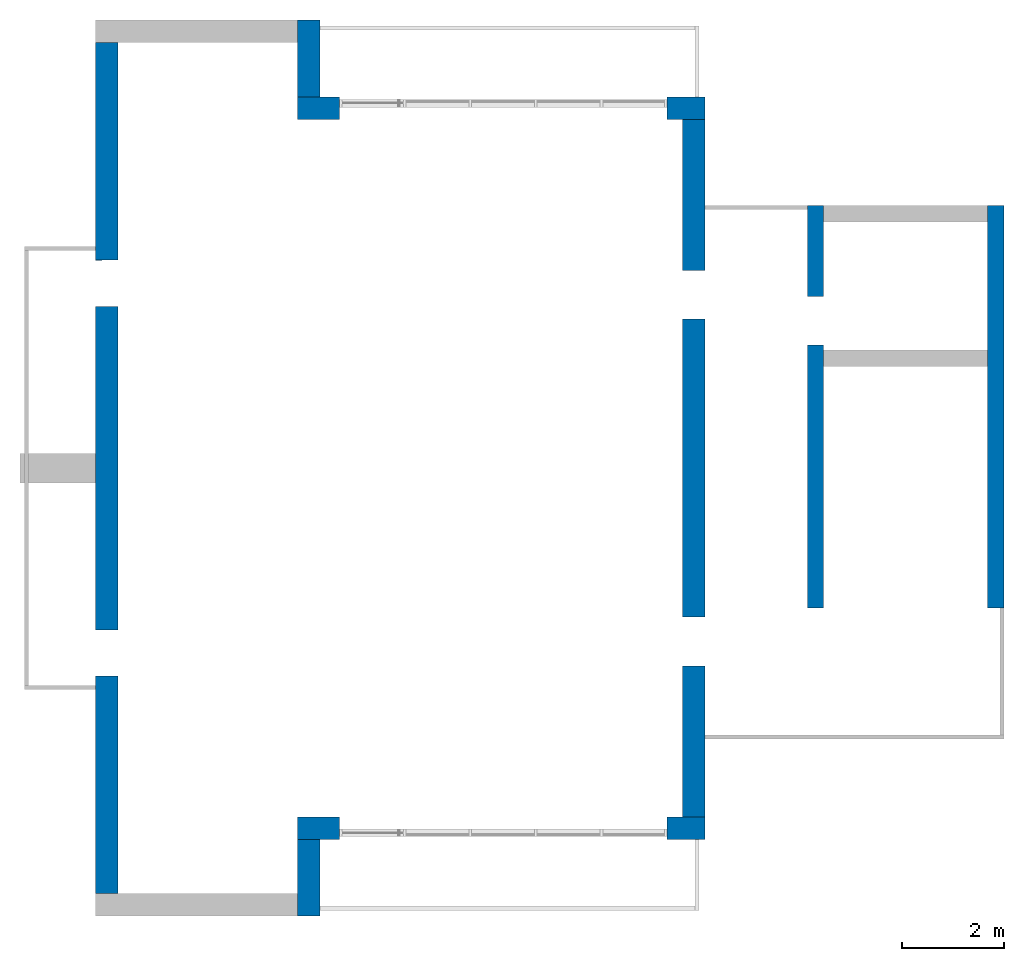
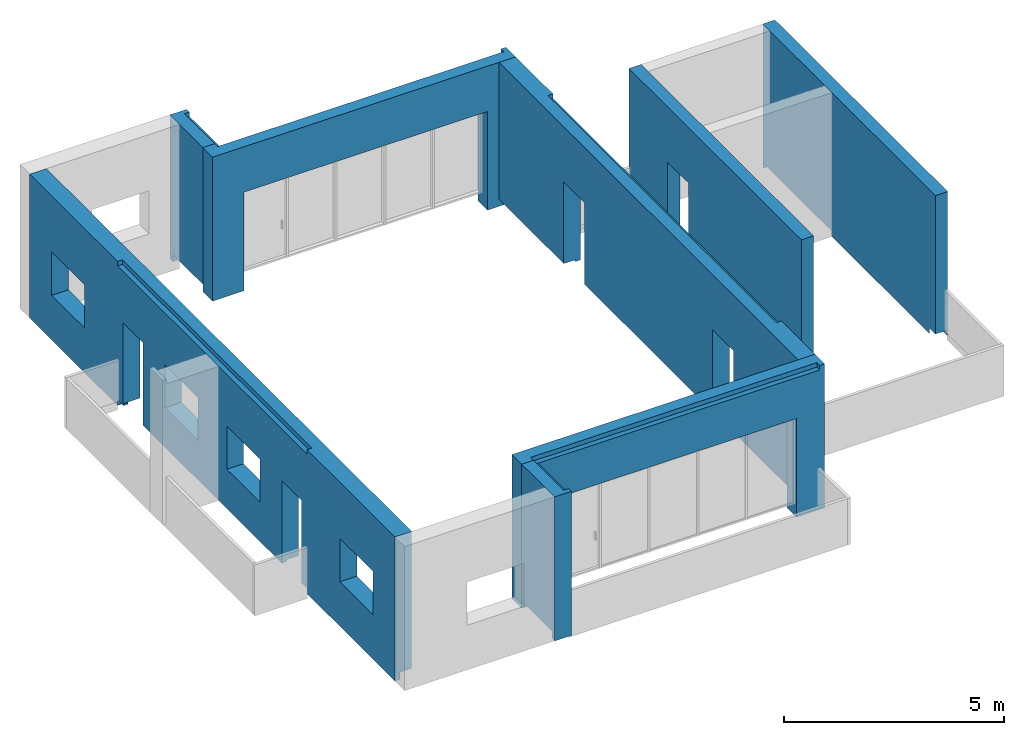
# One storey, part 3 of 4: 8 walls.
"""IFC2X3 building model written with IfcOpenShell, lengths in millimetres."""

from ifc_helpers import new_model, entity, si_unit, converted_unit, derived_unit, direction, frame, origin, place, context, subcontext, project, spatial, faceted_brep, material, layer, layer_set, type_object, element, save


model = new_model("IFC2X3")

# Units and contexts
model_context = context("Model", 3, precision=0.01, world=origin(), true_north=direction((6.12303176911189e-17, 1.0)))
body_context = subcontext(model_context, "Body", "Model", "MODEL_VIEW")
ifc_project = project(units=[si_unit("LENGTHUNIT", "METRE", prefix="MILLI"), si_unit("AREAUNIT", "SQUARE_METRE"), si_unit("VOLUMEUNIT", "CUBIC_METRE"), converted_unit("PLANEANGLEUNIT", "DEGREE", entity("IfcRatioMeasure", 0.0174532925199433), si_unit("PLANEANGLEUNIT", "RADIAN"), dimensions=[0, 0, 0, 0, 0, 0, 0]), si_unit("MASSUNIT", "GRAM", prefix="KILO"), derived_unit("MASSDENSITYUNIT", [(si_unit("MASSUNIT", "GRAM", prefix="KILO"), 1), (si_unit("LENGTHUNIT", "METRE"), -3)]), si_unit("TIMEUNIT", "SECOND"), si_unit("FREQUENCYUNIT", "HERTZ"), si_unit("THERMODYNAMICTEMPERATUREUNIT", "DEGREE_CELSIUS"), derived_unit("THERMALTRANSMITTANCEUNIT", [(si_unit("MASSUNIT", "GRAM", prefix="KILO"), 1), (si_unit("THERMODYNAMICTEMPERATUREUNIT", "KELVIN"), -1), (si_unit("TIMEUNIT", "SECOND"), -3)]), derived_unit("VOLUMETRICFLOWRATEUNIT", [(si_unit("LENGTHUNIT", "METRE"), 3), (si_unit("TIMEUNIT", "SECOND"), -1)]), si_unit("ELECTRICCURRENTUNIT", "AMPERE"), si_unit("ELECTRICVOLTAGEUNIT", "VOLT"), si_unit("POWERUNIT", "WATT"), si_unit("FORCEUNIT", "NEWTON", prefix="KILO"), si_unit("ILLUMINANCEUNIT", "LUX"), si_unit("LUMINOUSFLUXUNIT", "LUMEN"), si_unit("LUMINOUSINTENSITYUNIT", "CANDELA"), derived_unit("USERDEFINED", [(si_unit("MASSUNIT", "GRAM", prefix="KILO"), -1), (si_unit("LENGTHUNIT", "METRE"), -2), (si_unit("TIMEUNIT", "SECOND"), 3), (si_unit("LUMINOUSFLUXUNIT", "LUMEN"), 1)]), derived_unit("LINEARVELOCITYUNIT", [(si_unit("LENGTHUNIT", "METRE"), 1), (si_unit("TIMEUNIT", "SECOND"), -1)]), si_unit("PRESSUREUNIT", "PASCAL"), derived_unit("USERDEFINED", [(si_unit("LENGTHUNIT", "METRE"), -2), (si_unit("MASSUNIT", "GRAM", prefix="KILO"), 1), (si_unit("TIMEUNIT", "SECOND"), -2)])], contexts=[model_context])

# Site, building, storey
site_placement = place(None, origin())
site = spatial("IfcSite", under=ifc_project, at=site_placement, CompositionType="ELEMENT")
building_placement = place(site_placement, origin())
building = spatial("IfcBuilding", under=site, at=building_placement, CompositionType="ELEMENT")
storey_placement = place(building_placement, frame((0.0, 0.0, 8000.0)))
storey = spatial("IfcBuildingStorey", under=building, at=storey_placement, Name="02 Level", CompositionType="ELEMENT", Elevation=8000.0)

# Walls
ifc_material_1 = material(Name="03")
ifc_layer_1 = layer(ifc_material_1, 10.0)
ifc_material_2 = material()
ifc_layer_2 = layer(ifc_material_2, 120.0)
ifc_material_3 = material()
ifc_layer_3 = layer(ifc_material_3, 300.0)
ifc_layer_4 = layer(ifc_material_1, 10.0)
ifc_layer_set_1 = layer_set([ifc_layer_1, ifc_layer_2, ifc_layer_3, ifc_layer_4], Name="Basic Wall:00_fal+12 cm")
wall_type_1 = type_object("IfcWallType", Name="Basic Wall:00_fal+12 cm", PredefinedType="STANDARD", material=ifc_layer_set_1)
wall_1_placement = place(storey_placement, frame((28723.4900708518, -62021.23958514, -340.0), z_axis=(0.0, 0.0, 1.0), x_axis=(0.0, -1.0, 0.0)))
element("IfcWall", 1, at=wall_1_placement, inside=storey, type_object=wall_type_1, Name="Basic Wall:00_fal+12 cm", ObjectType="Basic Wall:00_fal+12 cm", context=body_context, shape_type="Brep", body=[
    faceted_brep([(13620.0, -220.0, 4000.0), (9620.0, -220.0, 4000.0), (9470.0, -220.0, 4000.0), (6970.0, -220.0, 4000.0), (6650.0, -220.0, 4000.0), (4150.0, -220.0, 4000.0), (4000.0, -220.0, 4000.0), (0.0, -220.0, 4000.0), (0.0, -220.0, 200.0), (2950.0, -220.0, 200.0), (2950.0, -220.0, 340.0), (2950.0, -220.0, 2465.0), (3900.0, -220.0, 2465.0), (3900.0, -220.0, 340.0), (3900.0, -220.0, 200.0), (4000.0, -220.0, 200.0), (4150.0, -220.0, 200.0), (6650.0, -220.0, 200.0), (6970.0, -220.0, 200.0), (9470.0, -220.0, 200.0), (9620.0, -220.0, 200.0), (9720.0, -220.0, 200.0), (9720.0, -220.0, 340.0), (9720.0, -220.0, 2465.0), (10670.0, -220.0, 2465.0), (10670.0, -220.0, 340.0), (10670.0, -220.0, 200.0), (13620.0, -220.0, 200.0), (10670.0, 220.0, 2465.0), (9720.0, 220.0, 2465.0), (9720.0, 220.0, 340.0), (9720.0, 220.0, 150.0), (3900.0, 220.0, 150.0), (3900.0, 220.0, 340.0), (3900.0, 220.0, 2465.0), (2950.0, 220.0, 2465.0), (2950.0, 220.0, 340.0), (2950.0, 220.0, 150.0), (1764.58460545632, 220.0, 150.0), (1694.58460545634, 220.0, 150.0), (1694.58460545634, 220.0, 0.0), (0.0, 220.0, 0.0), (0.0, 220.0, 4000.0), (1694.58460545634, 220.0, 4000.0), (1699.58460545631, 220.0, 4000.0), (1699.58460545631, 220.0, 3875.0), (12094.5846054563, 220.0, 3875.0), (12094.5846054563, 220.0, 4000.0), (13620.0, 220.0, 4000.0), (13620.0, 220.0, 0.0), (12094.5846054563, 220.0, 0.0), (12039.5846054563, 220.0, 0.0), (12039.5846054563, 220.0, 150.0), (12024.5846054563, 220.0, 150.0), (10670.0, 220.0, 150.0), (10670.0, 220.0, 340.0), (1694.58460545634, 90.0, 0.0), (0.0, 90.0, 0.0), (12094.5846054563, 90.0, 4000.0), (1699.58460545631, 90.0, 4000.0), (0.0, 90.0, 4000.0), (9720.0, -120.0, 200.0), (9720.0, 90.0, 200.0), (9720.0, 90.0, 150.0), (10670.0, 90.0, 150.0), (10670.0, 90.0, 200.0), (10670.0, -120.0, 200.0), (3900.0, 90.0, 150.0), (3900.0, 90.0, 200.0), (3900.0, -120.0, 200.0), (2950.0, -120.0, 200.0), (2950.0, 90.0, 200.0), (2950.0, 90.0, 150.0), (13620.0, 90.0, 200.0), (1694.58460545634, 90.0, 150.0), (0.0, 90.0, 200.0), (12039.5846054563, 90.0, 150.0), (12039.5846054563, 90.0, 0.0), (13620.0, 90.0, 0.0), (1699.58460545631, 90.0, 3875.0), (12094.5846054563, 90.0, 3875.0)], [[[0, 1, 2, 3, 4, 5, 6, 7, 8, 9, 10, 11, 12, 13, 14, 15, 16, 17, 18, 19, 20, 21, 22, 23, 24, 25, 26, 27]], [[28, 29, 30, 31, 32, 33, 34, 35, 36, 37, 38, 39, 40, 41, 42, 43, 44, 45, 46, 47, 48, 49, 50, 51, 52, 53, 54, 55]], [[41, 40, 56, 57]], [[7, 6, 5, 4, 3, 2, 1, 0, 48, 47, 58, 59, 44, 43, 42, 60]], [[29, 23, 22, 21, 61, 62, 63, 31, 30]], [[24, 23, 29, 28]], [[24, 28, 55, 54, 64, 65, 66, 26, 25]], [[12, 34, 33, 32, 67, 68, 69, 14, 13]], [[12, 11, 35, 34]], [[35, 11, 10, 9, 70, 71, 72, 37, 36]], [[73, 27, 26, 66, 65]], [[57, 56, 74, 72, 71, 75]], [[52, 76, 64, 54, 53]], [[76, 52, 51, 77]], [[39, 74, 56, 40]], [[48, 0, 27, 73, 78, 49]], [[7, 60, 42, 41, 57, 75, 8]], [[79, 80, 46, 45]], [[80, 79, 59, 58]], [[59, 79, 45, 44]], [[80, 58, 47, 46]], [[63, 67, 32, 31]], [[74, 39, 38, 37, 72]], [[77, 78, 73, 65, 64, 76]], [[62, 68, 67, 63]], [[8, 75, 71, 70, 9]], [[21, 20, 19, 18, 17, 16, 15, 14, 69, 68, 62, 61]], [[51, 50, 49, 78, 77]]]),
])
wall_2_placement = place(storey_placement, frame((21203.4900708518, -76081.2395851399, -340.0), z_axis=(0.0, 0.0, 1.0), x_axis=(0.0, -1.0, 0.0)))
element("IfcWall", 2, at=wall_2_placement, inside=storey, type_object=wall_type_1, Name="Basic Wall:00_fal+12 cm", ObjectType="Basic Wall:00_fal+12 cm", context=body_context, shape_type="Brep", body=[
    faceted_brep([(1500.0, -220.0, 4000.0), (1370.0, -220.0, 4000.0), (1060.0, -220.0, 4000.0), (0.0, -220.0, 4000.0), (0.0, -220.0, 200.0), (1370.0, -220.0, 200.0), (1370.0, -220.0, 0.0), (1500.0, -220.0, 0.0), (1500.0, 220.0, 4000.0), (1500.0, 220.0, 0.0), (1370.0, 220.0, 0.0), (1370.0, 220.0, 150.0), (1305.0, 220.0, 150.0), (0.0, 220.0, 150.0), (0.0, 220.0, 3875.0), (1370.0, 220.0, 3875.0), (1370.0, 220.0, 4000.0), (1370.0, 90.0, 0.0), (1370.0, 90.0, 4000.0), (0.0, 90.0, 4000.0), (1370.0, 90.0, 200.0), (0.0, 90.0, 200.0), (1370.0, 90.0, 150.0), (0.0, 90.0, 150.0), (0.0, 90.0, 3875.0), (1370.0, 90.0, 3875.0)], [[[0, 1, 2, 3, 4, 5, 6, 7]], [[8, 9, 10, 11, 12, 13, 14, 15, 16]], [[9, 7, 6, 17, 10]], [[3, 2, 1, 0, 8, 16, 18, 19]], [[7, 9, 8, 0]], [[20, 5, 4, 21]], [[22, 20, 21, 23]], [[5, 20, 22, 11, 10, 17, 6]], [[11, 22, 23, 13, 12]], [[24, 25, 15, 14]], [[25, 18, 16, 15]], [[18, 25, 24, 19]], [[4, 3, 19, 24, 14, 13, 23, 21]]]),
])
wall_3_placement = place(storey_placement, frame((17263.4900708518, -77141.2395851399, -340.0), z_axis=(0.0, 0.0, 1.0), x_axis=(0.0, 1.0, 0.0)))
element("IfcWall", 3, at=wall_3_placement, inside=storey, type_object=wall_type_1, Name="Basic Wall:00_fal+12 cm", ObjectType="Basic Wall:00_fal+12 cm", context=body_context, shape_type="Brep", body=[
    faceted_brep([(16620.0, -220.0, 4000.0), (12620.0, -220.0, 4000.0), (12470.0, -220.0, 4000.0), (8470.0, -220.0, 4000.0), (8150.0, -220.0, 4000.0), (4150.0, -220.0, 4000.0), (4000.0, -220.0, 4000.0), (0.0, -220.0, 4000.0), (0.0, -220.0, 200.0), (4000.0, -220.0, 200.0), (4150.0, -220.0, 200.0), (4250.0, -220.0, 200.0), (4250.0, -220.0, 2440.0), (5150.0, -220.0, 2440.0), (5150.0, -220.0, 200.0), (8150.0, -220.0, 200.0), (8470.0, -220.0, 200.0), (11470.0, -220.0, 200.0), (11470.0, -220.0, 2440.0), (12370.0, -220.0, 2440.0), (12370.0, -220.0, 200.0), (12470.0, -220.0, 200.0), (12620.0, -220.0, 200.0), (16620.0, -220.0, 200.0), (7650.0, -220.0, 2440.0), (7650.0, -220.0, 1240.0), (6150.0, -220.0, 1240.0), (6150.0, -220.0, 2440.0), (2500.0, -220.0, 2440.0), (2500.0, -220.0, 1240.0), (1000.0, -220.0, 1240.0), (1000.0, -220.0, 2440.0), (8970.0, -220.0, 1240.0), (8970.0, -220.0, 2440.0), (10470.0, -220.0, 2440.0), (10470.0, -220.0, 1240.0), (14120.0, -220.0, 1240.0), (14120.0, -220.0, 2440.0), (15620.0, -220.0, 2440.0), (15620.0, -220.0, 1240.0), (0.0, 220.0, 0.0), (0.0, 220.0, 4000.0), (4000.0, 220.0, 4000.0), (4000.0, 220.0, 3875.0), (8020.0, 220.0, 3875.0), (8590.0, 220.0, 3875.0), (12620.0, 220.0, 3875.0), (12620.0, 220.0, 4000.0), (16620.0, 220.0, 4000.0), (16620.0, 220.0, 0.0), (12620.0, 220.0, 0.0), (12620.0, 220.0, 150.0), (12555.0, 220.0, 150.0), (12360.0, 220.0, 150.0), (12360.0, 220.0, 200.0), (12370.0, 220.0, 200.0), (12370.0, 220.0, 340.0), (12370.0, 220.0, 2440.0), (11470.0, 220.0, 2440.0), (11470.0, 220.0, 340.0), (11460.0, 220.0, 340.0), (11460.0, 220.0, 150.0), (8590.0, 220.0, 150.0), (8020.0, 220.0, 150.0), (5150.0, 220.0, 150.0), (5150.0, 220.0, 340.0), (5150.0, 220.0, 2440.0), (4250.0, 220.0, 2440.0), (4250.0, 220.0, 340.0), (4250.0, 220.0, 150.0), (4065.0, 220.0, 150.0), (4000.0, 220.0, 150.0), (4000.0, 220.0, 0.0), (7650.0, 220.0, 1240.0), (7650.0, 220.0, 2440.0), (6150.0, 220.0, 2440.0), (6150.0, 220.0, 1240.0), (2500.0, 220.0, 1240.0), (2500.0, 220.0, 2440.0), (1000.0, 220.0, 2440.0), (1000.0, 220.0, 1240.0), (8970.0, 220.0, 2440.0), (8970.0, 220.0, 1240.0), (10470.0, 220.0, 1240.0), (10470.0, 220.0, 2440.0), (14120.0, 220.0, 2440.0), (14120.0, 220.0, 1240.0), (15620.0, 220.0, 1240.0), (15620.0, 220.0, 2440.0), (0.0, 90.0, 0.0), (4000.0, 90.0, 0.0), (16620.0, 90.0, 4000.0), (12620.0, 90.0, 4000.0), (4000.0, 90.0, 4000.0), (0.0, 90.0, 4000.0), (0.0, 90.0, 200.0), (4250.0, -120.0, 200.0), (4250.0, 90.0, 200.0), (4250.0, 90.0, 150.0), (5150.0, 90.0, 150.0), (5150.0, 90.0, 200.0), (5150.0, -120.0, 200.0), (16620.0, 90.0, 200.0), (16620.0, 90.0, 0.0), (12370.0, 90.0, 200.0), (12360.0, 90.0, 200.0), (11470.0, -120.0, 200.0), (11470.0, -120.0, 340.0), (4000.0, 90.0, 150.0), (12620.0, 90.0, 150.0), (12620.0, 90.0, 0.0), (4000.0, 90.0, 3875.0), (12620.0, 90.0, 3875.0), (11460.0, -120.0, 340.0), (11460.0, -120.0, 200.0), (11460.0, 90.0, 200.0), (11460.0, 90.0, 150.0), (12360.0, 90.0, 150.0)], [[[0, 1, 2, 3, 4, 5, 6, 7, 8, 9, 10, 11, 12, 13, 14, 15, 16, 17, 18, 19, 20, 21, 22, 23], [24, 25, 26, 27], [28, 29, 30, 31], [32, 33, 34, 35], [36, 37, 38, 39]], [[40, 41, 42, 43, 44, 45, 46, 47, 48, 49, 50, 51, 52, 53, 54, 55, 56, 57, 58, 59, 60, 61, 62, 63, 64, 65, 66, 67, 68, 69, 70, 71, 72], [73, 74, 75, 76], [77, 78, 79, 80], [81, 82, 83, 84], [85, 86, 87, 88]], [[89, 40, 72, 90]], [[7, 6, 5, 4, 3, 2, 1, 0, 91, 48, 47, 92, 93, 42, 41, 94]], [[7, 94, 41, 40, 89, 95, 8]], [[12, 11, 96, 97, 98, 69, 68, 67]], [[13, 12, 67, 66]], [[14, 13, 66, 65, 64, 99, 100, 101]], [[49, 48, 91, 0, 23, 102, 103]], [[104, 55, 54, 105]], [[20, 19, 57, 56, 55, 104]], [[58, 57, 19, 18]], [[18, 17, 106, 107, 59, 58]], [[74, 73, 25, 24]], [[75, 74, 24, 27]], [[76, 75, 27, 26]], [[73, 76, 26, 25]], [[78, 77, 29, 28]], [[79, 78, 28, 31]], [[80, 79, 31, 30]], [[77, 80, 30, 29]], [[33, 32, 82, 81]], [[34, 33, 81, 84]], [[35, 34, 84, 83]], [[32, 35, 83, 82]], [[37, 36, 86, 85]], [[38, 37, 85, 88]], [[39, 38, 88, 87]], [[36, 39, 87, 86]], [[23, 22, 21, 20, 104, 102]], [[95, 89, 90, 108, 98, 97]], [[108, 71, 70, 69, 98]], [[109, 51, 50, 110]], [[71, 108, 90, 72]], [[111, 112, 46, 45, 44, 43]], [[112, 92, 47, 46]], [[112, 111, 93, 92]], [[93, 111, 43, 42]], [[113, 60, 59, 107]], [[60, 113, 114, 115, 116, 61]], [[113, 107, 106, 114]], [[54, 53, 117, 105]], [[51, 109, 117, 53, 52]], [[64, 63, 62, 61, 116, 99]], [[100, 99, 116, 115]], [[103, 102, 104, 105, 117, 109, 110]], [[17, 16, 15, 14, 101, 100, 115, 114, 106]], [[8, 95, 97, 96, 11, 10, 9]], [[49, 103, 110, 50]]]),
])
wall_4_placement = place(storey_placement, frame((21203.4900708518, -61581.2395851399, -340.0), z_axis=(0.0, 0.0, 1.0), x_axis=(0.0, 1.0, 0.0)))
element("IfcWall", 4, at=wall_4_placement, inside=storey, type_object=wall_type_1, Name="Basic Wall:00_fal+12 cm", ObjectType="Basic Wall:00_fal+12 cm", context=body_context, shape_type="Brep", body=[
    faceted_brep([(1500.0, -220.0, 0.0), (1500.0, -220.0, 4000.0), (1370.0, -220.0, 4000.0), (1370.0, -220.0, 3875.0), (0.0, -220.0, 3875.0), (0.0, -220.0, 150.0), (1305.0, -220.0, 150.0), (1370.0, -220.0, 150.0), (1370.0, -220.0, 0.0), (0.0, 220.0, 4000.0), (1060.0, 220.0, 4000.0), (1370.0, 220.0, 4000.0), (1500.0, 220.0, 4000.0), (1500.0, 220.0, 0.0), (1370.0, 220.0, 0.0), (1370.0, 220.0, 200.0), (0.0, 220.0, 200.0), (1370.0, -90.0, 0.0), (0.0, -90.0, 4000.0), (1370.0, -90.0, 4000.0), (0.0, -90.0, 200.0), (0.0, -90.0, 150.0), (0.0, -90.0, 3875.0), (1370.0, -90.0, 200.0), (1370.0, -90.0, 150.0), (1370.0, -90.0, 3875.0)], [[[0, 1, 2, 3, 4, 5, 6, 7, 8]], [[9, 10, 11, 12, 13, 14, 15, 16]], [[13, 0, 8, 17, 14]], [[12, 11, 10, 9, 18, 19, 2, 1]], [[0, 13, 12, 1]], [[9, 16, 20, 21, 5, 4, 22, 18]], [[15, 23, 20, 16]], [[23, 15, 14, 17, 8, 7, 24]], [[20, 23, 24, 21]], [[24, 7, 6, 5, 21]], [[3, 25, 22, 4]], [[25, 19, 18, 22]], [[19, 25, 3, 2]]]),
])
wall_5_placement = place(storey_placement, frame((28943.4900708518, -75861.2395851399, -340.0), z_axis=(0.0, 0.0, 1.0), x_axis=(-1.0, 0.0, 0.0)))
element("IfcWall", 5, at=wall_5_placement, inside=storey, type_object=wall_type_1, Name="Basic Wall:00_fal+12 cm", ObjectType="Basic Wall:00_fal+12 cm", context=body_context, shape_type="Brep", body=[
    faceted_brep([(0.0, -220.0, 0.0), (130.0, -220.0, 0.0), (740.0, -220.0, 0.0), (740.0, -220.0, 200.0), (740.0, -220.0, 340.0), (740.0, -220.0, 2740.0), (7140.0, -220.0, 2740.0), (7140.0, -220.0, 340.0), (7140.0, -220.0, 200.0), (7140.0, -220.0, 0.0), (7960.0, -220.0, 0.0), (7960.0, -220.0, 200.0), (7960.0, -220.0, 4000.0), (7640.0, -220.0, 4000.0), (440.0, -220.0, 4000.0), (0.0, -220.0, 4000.0), (740.0, 220.0, 0.0), (0.0, 220.0, 0.0), (0.0, 220.0, 4000.0), (130.0, 220.0, 4000.0), (130.0, 220.0, 3875.0), (7520.0, 220.0, 3875.0), (7650.0, 220.0, 3875.0), (7650.0, 220.0, 4000.0), (7960.0, 220.0, 4000.0), (7960.0, 220.0, 200.0), (7960.0, 220.0, 0.0), (7140.0, 220.0, 0.0), (7140.0, 220.0, 150.0), (7140.0, 220.0, 340.0), (7140.0, 220.0, 2740.0), (740.0, 220.0, 2740.0), (740.0, 220.0, 340.0), (740.0, 220.0, 150.0), (7650.0, 90.0, 4000.0), (130.0, 90.0, 4000.0), (130.0, 90.0, 3875.0), (7650.0, 90.0, 3875.0)], [[[0, 1, 2, 3, 4, 5, 6, 7, 8, 9, 10, 11, 12, 13, 14, 15]], [[16, 17, 18, 19, 20, 21, 22, 23, 24, 25, 26, 27, 28, 29, 30, 31, 32, 33]], [[5, 31, 30, 6]], [[2, 1, 0, 17, 16]], [[15, 14, 13, 12, 24, 23, 34, 35, 19, 18]], [[31, 5, 4, 3, 2, 16, 33, 32]], [[6, 30, 29, 28, 27, 9, 8, 7]], [[10, 9, 27, 26]], [[17, 0, 15, 18]], [[10, 26, 25, 24, 12, 11]], [[36, 37, 22, 21, 20]], [[37, 36, 35, 34]], [[35, 36, 20, 19]], [[37, 34, 23, 22]]]),
])
wall_6_placement = place(storey_placement, frame((28943.4900708518, -61801.23958514, -340.0), z_axis=(0.0, 0.0, 1.0), x_axis=(-1.0, 0.0, 0.0)))
element("IfcWall", 6, at=wall_6_placement, inside=storey, type_object=wall_type_1, Name="Basic Wall:00_fal+12 cm", ObjectType="Basic Wall:00_fal+12 cm", context=body_context, shape_type="Brep", body=[
    faceted_brep([(0.0, -220.0, 0.0), (740.0, -220.0, 0.0), (740.0, -220.0, 150.0), (740.0, -220.0, 340.0), (740.0, -220.0, 2740.0), (7140.0, -220.0, 2740.0), (7140.0, -220.0, 340.0), (7140.0, -220.0, 150.0), (7140.0, -220.0, 0.0), (7520.0, -220.0, 0.0), (7960.0, -220.0, 0.0), (7960.0, -220.0, 4000.0), (7650.0, -220.0, 4000.0), (7650.0, -220.0, 3875.0), (130.0, -220.0, 3875.0), (130.0, -220.0, 4000.0), (0.0, -220.0, 4000.0), (740.0, 220.0, 0.0), (130.0, 220.0, 0.0), (0.0, 220.0, 0.0), (0.0, 220.0, 4000.0), (130.0, 220.0, 4000.0), (440.0, 220.0, 4000.0), (7640.0, 220.0, 4000.0), (7960.0, 220.0, 4000.0), (7960.0, 220.0, 200.0), (7960.0, 220.0, 0.0), (7140.0, 220.0, 0.0), (7140.0, 220.0, 200.0), (7140.0, 220.0, 340.0), (7140.0, 220.0, 2740.0), (740.0, 220.0, 2740.0), (740.0, 220.0, 340.0), (740.0, 220.0, 200.0), (130.0, -90.0, 4000.0), (7650.0, -90.0, 4000.0), (7650.0, -90.0, 3875.0), (130.0, -90.0, 3875.0)], [[[0, 1, 2, 3, 4, 5, 6, 7, 8, 9, 10, 11, 12, 13, 14, 15, 16]], [[17, 18, 19, 20, 21, 22, 23, 24, 25, 26, 27, 28, 29, 30, 31, 32, 33]], [[4, 31, 30, 5]], [[1, 0, 19, 18, 17]], [[24, 23, 22, 21, 20, 16, 15, 34, 35, 12, 11]], [[31, 4, 3, 2, 1, 17, 33, 32]], [[5, 30, 29, 28, 27, 8, 7, 6]], [[10, 9, 8, 27, 26]], [[19, 0, 16, 20]], [[36, 37, 14, 13]], [[35, 36, 13, 12]], [[37, 34, 15, 14]], [[37, 36, 35, 34]], [[10, 26, 25, 24, 11]]]),
])
ifc_layer_5 = layer(ifc_material_1, 10.0)
ifc_layer_6 = layer(ifc_material_3, 300.0)
ifc_layer_7 = layer(ifc_material_1, 10.0)
ifc_layer_set_2 = layer_set([ifc_layer_5, ifc_layer_6, ifc_layer_7], Name="Basic Wall:00_fal 300 mm")
wall_type_2 = type_object("IfcWallType", Name="Basic Wall:00_fal 300 mm", PredefinedType="STANDARD", material=ifc_layer_set_2)
wall_7_placement = place(storey_placement, frame((31103.4900708518, -63705.8241905964, -340.0), z_axis=(0.0, 0.0, 1.0), x_axis=(0.0, -1.0, 0.0)))
element("IfcWall", 7, at=wall_7_placement, inside=storey, type_object=wall_type_2, Name="Basic Wall:00_fal 300 mm", ObjectType="Basic Wall:00_fal 300 mm", context=body_context, shape_type="Brep", body=[
    faceted_brep([(7855.0, -160.0, 4000.0), (15.0, -160.0, 4000.0), (0.0, -160.0, 4000.0), (0.0, -160.0, 3875.0), (0.0, -160.0, 1290.0), (0.0, -160.0, 0.0), (10.0, -160.0, 0.0), (10.0, -160.0, 150.0), (80.0, -160.0, 150.0), (1770.0, -160.0, 150.0), (1770.0, -160.0, 340.0), (1770.0, -160.0, 2465.0), (2720.0, -160.0, 2465.0), (2720.0, -160.0, 340.0), (2720.0, -160.0, 150.0), (7855.0, -160.0, 150.0), (7855.0, -160.0, 340.0), (0.0, 160.0, 4000.0), (15.0, 160.0, 4000.0), (320.0, 160.0, 4000.0), (2820.0, 160.0, 4000.0), (3130.0, 160.0, 4000.0), (3140.0, 160.0, 4000.0), (7855.0, 160.0, 4000.0), (7855.0, 160.0, 340.0), (7855.0, 160.0, 150.0), (7855.0, 160.0, 0.0), (3140.0, 160.0, 0.0), (3130.0, 160.0, 0.0), (3130.0, 160.0, 150.0), (2820.0, 160.0, 150.0), (2720.0, 160.0, 150.0), (2720.0, 160.0, 340.0), (2720.0, 160.0, 2465.0), (1770.0, 160.0, 2465.0), (1770.0, 160.0, 340.0), (1770.0, 160.0, 150.0), (320.0, 160.0, 150.0), (10.0, 160.0, 150.0), (10.0, 160.0, 0.0), (0.0, 160.0, 0.0), (7855.0, 150.0, 150.0), (7855.0, 150.0, 0.0), (2720.0, 60.0, 150.0), (1770.0, 60.0, 150.0), (3130.0, 150.0, 150.0), (3130.0, 150.0, 0.0)], [[[0, 1, 2, 3, 4, 5, 6, 7, 8, 9, 10, 11, 12, 13, 14, 15, 16]], [[17, 18, 19, 20, 21, 22, 23, 24, 25, 26, 27, 28, 29, 30, 31, 32, 33, 34, 35, 36, 37, 38, 39, 40]], [[6, 5, 40, 39]], [[23, 0, 16, 15, 41, 42, 26, 25, 24]], [[2, 1, 0, 23, 22, 21, 20, 19, 18, 17]], [[12, 33, 32, 31, 43, 14, 13]], [[33, 12, 11, 34]], [[34, 11, 10, 9, 44, 36, 35]], [[45, 41, 15, 14, 43, 31, 30, 29]], [[38, 7, 6, 39]], [[46, 45, 29, 28]], [[41, 45, 46, 42]], [[40, 5, 4, 3, 2, 17]], [[7, 38, 37, 36, 44, 9, 8]], [[28, 27, 26, 42, 46]]]),
])
wall_8_placement = place(storey_placement, frame((34623.4900708518, -63705.8241905964, -340.0), z_axis=(0.0, 0.0, 1.0), x_axis=(0.0, -1.0, 0.0)))
element("IfcWall", 8, at=wall_8_placement, inside=storey, type_object=wall_type_2, Name="Basic Wall:00_fal 300 mm", ObjectType="Basic Wall:00_fal 300 mm", context=body_context, shape_type="Brep", body=[
    faceted_brep([(7855.0, -160.0, 4000.0), (7575.0, -160.0, 4000.0), (3140.0, -160.0, 4000.0), (3130.0, -160.0, 4000.0), (2820.0, -160.0, 4000.0), (320.0, -160.0, 4000.0), (15.0, -160.0, 4000.0), (10.0, -160.0, 4000.0), (0.0, -160.0, 4000.0), (0.0, -160.0, 0.0), (10.0, -160.0, 0.0), (10.0, -160.0, 150.0), (15.0, -160.0, 150.0), (320.0, -160.0, 150.0), (2820.0, -160.0, 150.0), (3130.0, -160.0, 150.0), (3130.0, -160.0, 0.0), (3140.0, -160.0, 0.0), (7575.0, -160.0, 0.0), (7575.0, -160.0, 150.0), (7855.0, -160.0, 150.0), (7855.0, 160.0, 0.0), (0.0, 160.0, 0.0), (0.0, 160.0, 4000.0), (7855.0, 160.0, 4000.0), (7855.0, 160.0, 1290.0), (3130.0, -150.0, 0.0), (7575.0, -150.0, 0.0), (7855.0, 150.0, 4000.0), (7575.0, -150.0, 150.0), (3130.0, -150.0, 150.0), (10.0, 150.0, 150.0), (7855.0, 150.0, 150.0), (7855.0, 80.0, 150.0), (10.0, 150.0, 0.0), (7855.0, 150.0, 0.0)], [[[0, 1, 2, 3, 4, 5, 6, 7, 8, 9, 10, 11, 12, 13, 14, 15, 16, 17, 18, 19, 20]], [[21, 22, 23, 24, 25]], [[18, 17, 16, 26, 27]], [[8, 7, 6, 5, 4, 3, 2, 1, 0, 28, 24, 23]], [[9, 8, 23, 22]], [[29, 30, 15, 14, 13, 12, 11, 31, 32, 33, 20, 19]], [[31, 34, 35, 32]], [[34, 31, 11, 10]], [[30, 29, 27, 26]], [[30, 26, 16, 15]], [[27, 29, 19, 18]], [[24, 28, 0, 20, 33, 32, 35, 21, 25]], [[22, 21, 35, 34, 10, 9]]]),
])

save(model, "model.ifc")
